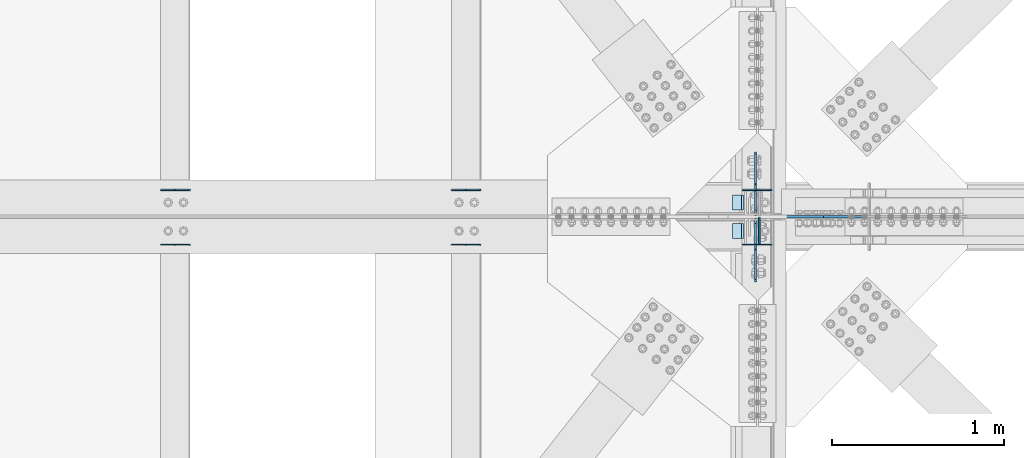
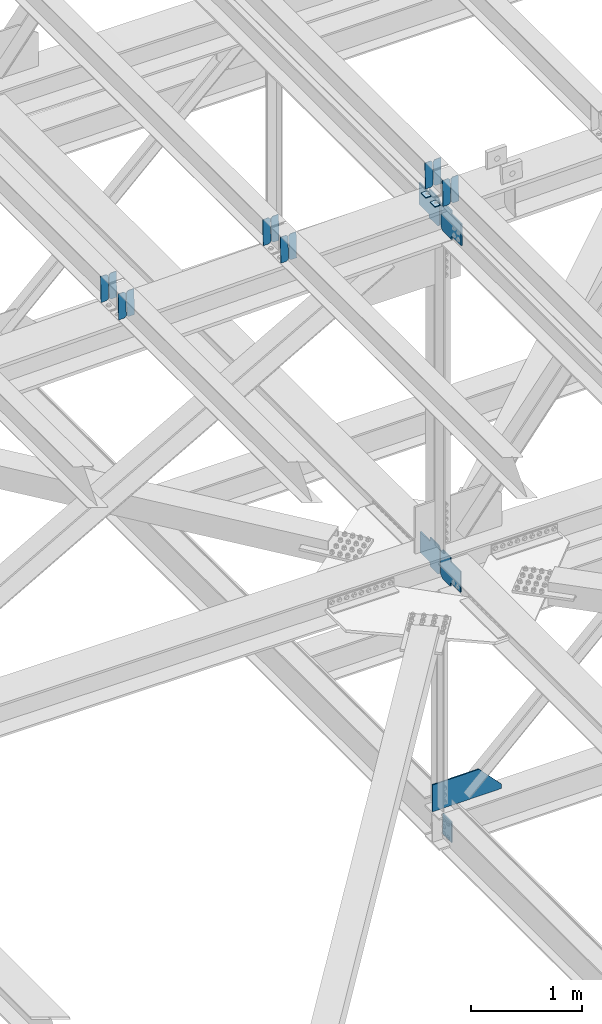
# One storey, part 3321 of 3843: 20 plates, 9 elements without a shape of their own.
"""IFC2X3 building model written with IfcOpenShell, lengths in millimetres."""

from ifc_helpers import new_model, si_unit, frame, origin_with_axes, place, context, subcontext, project, spatial, faceted_brep, material, type_object, element, aggregate, save


model = new_model("IFC2X3")

# Units and contexts
model_context = context("Model", 3, precision=1e-05, world=origin_with_axes())
body_context = subcontext(model_context, "Body", "Model", "MODEL_VIEW")
ifc_project = project(units=[si_unit("LENGTHUNIT", "METRE", prefix="MILLI"), si_unit("AREAUNIT", "SQUARE_METRE"), si_unit("VOLUMEUNIT", "CUBIC_METRE"), si_unit("MASSUNIT", "GRAM", prefix="KILO"), si_unit("TIMEUNIT", "SECOND"), si_unit("PLANEANGLEUNIT", "RADIAN"), si_unit("SOLIDANGLEUNIT", "STERADIAN"), si_unit("THERMODYNAMICTEMPERATUREUNIT", "DEGREE_CELSIUS"), si_unit("LUMINOUSINTENSITYUNIT", "LUMEN")], contexts=[model_context])

# Site, building, storey
site_placement = place(None, origin_with_axes())
site = spatial("IfcSite", under=ifc_project, at=site_placement, CompositionType="ELEMENT")
building_placement = place(site_placement, origin_with_axes())
building = spatial("IfcBuilding", under=site, at=building_placement, Name="Undefined", CompositionType="ELEMENT")
storey_placement = place(building_placement, origin_with_axes())
storey = spatial("IfcBuildingStorey", under=building, at=storey_placement, Name="Undefined", CompositionType="ELEMENT", Elevation=0.0)

# Assembly, plates
assembly_1_placement = place(storey_placement, origin_with_axes())
assembly_1 = element("IfcElementAssembly", 1, at=assembly_1_placement, inside=storey, Name="BEAM", AssemblyPlace="NOTDEFINED", PredefinedType="RIGID_FRAME")
ifc_material = material(Name="STEEL/A572-50")
plate_type_1 = type_object("IfcPlateType", PredefinedType="NOTDEFINED")
plate_1_placement = place(assembly_1_placement, frame((77095.0964783465, 59070.7010897801, 46382.6555246652), z_axis=(-0.0211520976064639, 0.000583214000143924, 0.999776099248365), x_axis=(-0.999776269355723, -1.23390000258365e-05, -0.0211520940075068)))
plate_1 = element("IfcPlate", 2, at=plate_1_placement, type_object=plate_type_1, material=ifc_material, Name="PLATE", context=body_context, shape_type="Brep", body=[
    faceted_brep([(0.0, -3.17499999999927, 0.0), (6.83940015733242e-10, -3.17499999996653, 288.924999998613), (6.54836185276508e-10, 3.17500000001746, 288.924999998591), (0.0, 3.17499999999927, 0.0), (60.3250007643655, -3.17500000017753, 288.924999998606), (60.3250007643219, 3.17499999979918, 288.924999998584), (79.3750000013097, -3.17500000025029, 269.875000761494), (79.375000001266, 3.17499999972642, 269.875000761487), (79.375000000713, -3.17500000026484, 19.0499992370605), (79.3750000006985, 3.17499999971187, 19.0499992370533), (60.325000763667, -3.17500000020664, -1.45519152283669e-11), (60.3250007636234, 3.17499999977736, -3.63797880709171e-11)], [[[0, 1, 2, 3]], [[1, 4, 5, 2]], [[4, 6, 7, 5]], [[6, 8, 9, 7]], [[8, 10, 11, 9]], [[10, 0, 3, 11]], [[5, 7, 9, 11, 3, 2]], [[10, 8, 6, 4, 1, 0]]]),
])
plate_2_placement = place(assembly_1_placement, frame((77009.3906576562, 59070.7000326944, 46380.8422613715), z_axis=(-0.0211520976064639, 0.000583214000143924, 0.999776099248365), x_axis=(-0.999776269355723, -1.23390000258365e-05, -0.0211520940075068)))
plate_2 = element("IfcPlate", 3, at=plate_2_placement, type_object=plate_type_1, material=ifc_material, Name="PLATE", context=body_context, shape_type="Brep", body=[
    faceted_brep([(4.36557456851006e-11, -3.17499999998836, 19.0499992370969), (6.11180439591408e-10, -3.17499999996653, 269.875000761516), (5.96628524363041e-10, 3.17500000001746, 269.875000761502), (1.45519152283669e-11, 3.17499999998836, 19.0499992370824), (19.0499992376572, -3.17500000003201, 288.924999998606), (19.0499992376281, 3.1749999999447, 288.924999998584), (79.3750000013242, -3.17500000025029, 288.924999998591), (79.3750000013097, 3.1749999997337, 288.92499999857), (79.3750000006548, -3.17500000026484, -2.18278728425503e-11), (79.3750000006403, 3.17499999969732, -2.91038304567337e-11), (19.0499992370023, -3.17500000005384, 0.0), (19.0499992369587, 3.17499999992287, -1.45519152283669e-11)], [[[0, 1, 2, 3]], [[1, 4, 5, 2]], [[4, 6, 7, 5]], [[6, 8, 9, 7]], [[8, 10, 11, 9]], [[10, 0, 3, 11]], [[5, 7, 9, 11, 3, 2]], [[10, 8, 6, 4, 1, 0]]]),
])

assembly_2_placement = place(storey_placement, origin_with_axes())
assembly_2 = element("IfcElementAssembly", 4, at=assembly_2_placement, inside=storey, Name="BEAM", AssemblyPlace="NOTDEFINED", PredefinedType="RIGID_FRAME")
plate_3_placement = place(assembly_2_placement, frame((77095.0964786592, 58753.5468079342, 46382.6529625895), z_axis=(-0.0211520975154853, -0.000575795999735418, 0.999776103550021), x_axis=(-0.999776269355722, 1.23390000256453e-05, -0.0211520940075457)))
plate_3 = element("IfcPlate", 5, at=plate_3_placement, type_object=plate_type_1, material=ifc_material, Name="PLATE", context=body_context, shape_type="Brep", body=[
    faceted_brep([(0.0, -3.17499999999927, 0.0), (6.83940015733242e-10, -3.17499999996653, 288.924999998613), (6.54836185276508e-10, 3.17500000001746, 288.924999998591), (0.0, 3.17499999999927, 0.0), (60.3250007643655, -3.17500000017753, 288.924999998606), (60.3250007643219, 3.17499999979918, 288.924999998584), (79.3750000013097, -3.17500000025029, 269.875000761494), (79.375000001266, 3.17499999972642, 269.875000761487), (79.375000000713, -3.17500000026484, 19.0499992370605), (79.3750000006985, 3.17499999971187, 19.0499992370533), (60.325000763667, -3.17500000020664, -1.45519152283669e-11), (60.3250007636234, 3.17499999977736, -3.63797880709171e-11)], [[[0, 1, 2, 3]], [[1, 4, 5, 2]], [[4, 6, 7, 5]], [[6, 8, 9, 7]], [[8, 10, 11, 9]], [[10, 0, 3, 11]], [[5, 7, 9, 11, 3, 2]], [[10, 8, 6, 4, 1, 0]]]),
])
plate_4_placement = place(assembly_2_placement, frame((77009.3906579689, 58753.5478522378, 46380.8396992902), z_axis=(-0.0211520975154853, -0.000575795999735418, 0.999776103550021), x_axis=(-0.999776269355722, 1.23390000256453e-05, -0.0211520940075457)))
plate_4 = element("IfcPlate", 6, at=plate_4_placement, type_object=plate_type_1, material=ifc_material, Name="PLATE", context=body_context, shape_type="Brep", body=[
    faceted_brep([(4.36557456851006e-11, -3.17499999998836, 19.0499992370969), (6.11180439591408e-10, -3.17499999996653, 269.875000761516), (5.96628524363041e-10, 3.17500000001746, 269.875000761502), (1.45519152283669e-11, 3.17499999998836, 19.0499992370824), (19.0499992376572, -3.17500000003201, 288.924999998606), (19.0499992376281, 3.1749999999447, 288.924999998584), (79.3750000013242, -3.17500000025029, 288.924999998591), (79.3750000013097, 3.1749999997337, 288.92499999857), (79.3750000006548, -3.17500000026484, -2.18278728425503e-11), (79.3750000006403, 3.17499999969732, -2.91038304567337e-11), (19.0499992370023, -3.17500000005384, 0.0), (19.0499992369587, 3.17499999992287, -1.45519152283669e-11)], [[[0, 1, 2, 3]], [[1, 4, 5, 2]], [[4, 6, 7, 5]], [[6, 8, 9, 7]], [[8, 10, 11, 9]], [[10, 0, 3, 11]], [[5, 7, 9, 11, 3, 2]], [[10, 8, 6, 4, 1, 0]]]),
])

assembly_3_placement = place(storey_placement, origin_with_axes())
assembly_3 = element("IfcElementAssembly", 7, at=assembly_3_placement, inside=storey, Name="BEAM", AssemblyPlace="NOTDEFINED", PredefinedType="RIGID_FRAME")
plate_5_placement = place(assembly_3_placement, frame((75405.9964817842, 59070.7097280611, 46349.1858286535), z_axis=(-0.0211520982414222, 0.000553894999946352, 0.999776115908114), x_axis=(-0.999776269355723, -1.23390000258365e-05, -0.0211520940075068)))
plate_5 = element("IfcPlate", 8, at=plate_5_placement, type_object=plate_type_1, material=ifc_material, Name="PLATE", context=body_context, shape_type="Brep", body=[
    faceted_brep([(0.0, -3.17499999999927, 0.0), (6.83940015733242e-10, -3.17499999996653, 288.924999998613), (6.54836185276508e-10, 3.17500000001746, 288.924999998591), (0.0, 3.17499999999927, 0.0), (60.3250007643655, -3.17500000017753, 288.924999998606), (60.3250007643219, 3.17499999979918, 288.924999998584), (79.3750000013097, -3.17500000025029, 269.875000761494), (79.375000001266, 3.17499999972642, 269.875000761487), (79.375000000713, -3.17500000026484, 19.0499992370605), (79.3750000006985, 3.17499999971187, 19.0499992370533), (60.325000763667, -3.17500000020664, -1.45519152283669e-11), (60.3250007636234, 3.17499999977736, -3.63797880709171e-11)], [[[0, 1, 2, 3]], [[1, 4, 5, 2]], [[4, 6, 7, 5]], [[6, 8, 9, 7]], [[8, 10, 11, 9]], [[10, 0, 3, 11]], [[5, 7, 9, 11, 3, 2]], [[10, 8, 6, 4, 1, 0]]]),
])
plate_6_placement = place(assembly_3_placement, frame((75320.2906610939, 59070.7087253666, 46347.3725653297), z_axis=(-0.0211520982414222, 0.000553894999946352, 0.999776115908114), x_axis=(-0.999776269355723, -1.23390000258365e-05, -0.0211520940075068)))
plate_6 = element("IfcPlate", 9, at=plate_6_placement, type_object=plate_type_1, material=ifc_material, Name="PLATE", context=body_context, shape_type="Brep", body=[
    faceted_brep([(4.36557456851006e-11, -3.17499999998836, 19.0499992370969), (6.11180439591408e-10, -3.17499999996653, 269.875000761516), (5.96628524363041e-10, 3.17500000001746, 269.875000761502), (1.45519152283669e-11, 3.17499999998836, 19.0499992370824), (19.0499992376572, -3.17500000003201, 288.924999998606), (19.0499992376281, 3.1749999999447, 288.924999998584), (79.3750000013242, -3.17500000025029, 288.924999998591), (79.3750000013097, 3.1749999997337, 288.92499999857), (79.3750000006548, -3.17500000026484, -2.18278728425503e-11), (79.3750000006403, 3.17499999969732, -2.91038304567337e-11), (19.0499992370023, -3.17500000005384, 0.0), (19.0499992369587, 3.17499999992287, -1.45519152283669e-11)], [[[0, 1, 2, 3]], [[1, 4, 5, 2]], [[4, 6, 7, 5]], [[6, 8, 9, 7]], [[8, 10, 11, 9]], [[10, 0, 3, 11]], [[5, 7, 9, 11, 3, 2]], [[10, 8, 6, 4, 1, 0]]]),
])
aggregate(assembly_3, [plate_5, plate_6])

assembly_4_placement = place(storey_placement, origin_with_axes())
assembly_4 = element("IfcElementAssembly", 10, at=assembly_4_placement, inside=storey, Name="BEAM", AssemblyPlace="NOTDEFINED", PredefinedType="RIGID_FRAME")
plate_7_placement = place(assembly_4_placement, frame((75405.99647837, 58753.539647001, 46349.1826475696), z_axis=(-0.0211520982287039, -0.000551804000038829, 0.99977611706465), x_axis=(-0.999776269355722, 1.23390000256453e-05, -0.0211520940075457)))
plate_7 = element("IfcPlate", 11, at=plate_7_placement, type_object=plate_type_1, material=ifc_material, Name="PLATE", context=body_context, shape_type="Brep", body=[
    faceted_brep([(0.0, -3.17499999999927, 0.0), (6.83940015733242e-10, -3.17499999996653, 288.924999998613), (6.54836185276508e-10, 3.17500000001746, 288.924999998591), (0.0, 3.17499999999927, 0.0), (60.3250007643655, -3.17500000017753, 288.924999998606), (60.3250007643219, 3.17499999979918, 288.924999998584), (79.3750000013097, -3.17500000025029, 269.875000761494), (79.375000001266, 3.17499999972642, 269.875000761487), (79.375000000713, -3.17500000026484, 19.0499992370605), (79.3750000006985, 3.17499999971187, 19.0499992370533), (60.325000763667, -3.17500000020664, -1.45519152283669e-11), (60.3250007636234, 3.17499999977736, -3.63797880709171e-11)], [[[0, 1, 2, 3]], [[1, 4, 5, 2]], [[4, 6, 7, 5]], [[6, 8, 9, 7]], [[8, 10, 11, 9]], [[10, 0, 3, 11]], [[5, 7, 9, 11, 3, 2]], [[10, 8, 6, 4, 1, 0]]]),
])
plate_8_placement = place(assembly_4_placement, frame((75320.2906576787, 58753.5406477902, 46347.369384245), z_axis=(-0.0211520982287039, -0.000551804000038829, 0.99977611706465), x_axis=(-0.999776269355722, 1.23390000256453e-05, -0.0211520940075457)))
plate_8 = element("IfcPlate", 12, at=plate_8_placement, type_object=plate_type_1, material=ifc_material, Name="PLATE", context=body_context, shape_type="Brep", body=[
    faceted_brep([(4.36557456851006e-11, -3.17499999998836, 19.0499992370969), (6.11180439591408e-10, -3.17499999996653, 269.875000761516), (5.96628524363041e-10, 3.17500000001746, 269.875000761502), (1.45519152283669e-11, 3.17499999998836, 19.0499992370824), (19.0499992376572, -3.17500000003201, 288.924999998606), (19.0499992376281, 3.1749999999447, 288.924999998584), (79.3750000013242, -3.17500000025029, 288.924999998591), (79.3750000013097, 3.1749999997337, 288.92499999857), (79.3750000006548, -3.17500000026484, -2.18278728425503e-11), (79.3750000006403, 3.17499999969732, -2.91038304567337e-11), (19.0499992370023, -3.17500000005384, 0.0), (19.0499992369587, 3.17499999992287, -1.45519152283669e-11)], [[[0, 1, 2, 3]], [[1, 4, 5, 2]], [[4, 6, 7, 5]], [[6, 8, 9, 7]], [[8, 10, 11, 9]], [[10, 0, 3, 11]], [[5, 7, 9, 11, 3, 2]], [[10, 8, 6, 4, 1, 0]]]),
])
aggregate(assembly_4, [plate_7, plate_8])

assembly_5_placement = place(storey_placement, origin_with_axes())
assembly_5 = element("IfcElementAssembly", 13, at=assembly_5_placement, inside=storey, Name="BEAM", AssemblyPlace="NOTDEFINED", PredefinedType="RIGID_FRAME")
plate_9_placement = place(assembly_5_placement, frame((73716.896478301, 59070.7155698843, 46315.1635973518), z_axis=(-0.0211520980283531, 0.000534327999768721, 0.999776126561636), x_axis=(-0.999776269357269, -1.03370000525781e-05, -0.0211520950075214)))
plate_9 = element("IfcPlate", 14, at=plate_9_placement, type_object=plate_type_1, material=ifc_material, Name="PLATE", context=body_context, shape_type="Brep", body=[
    faceted_brep([(0.0, -3.17499999999927, 0.0), (6.83940015733242e-10, -3.17499999996653, 288.924999998613), (6.54836185276508e-10, 3.17500000001746, 288.924999998591), (0.0, 3.17499999999927, 0.0), (60.3250007643655, -3.17500000017753, 288.924999998606), (60.3250007643219, 3.17499999979918, 288.924999998584), (79.3750000013097, -3.17500000025029, 269.875000761494), (79.375000001266, 3.17499999972642, 269.875000761487), (79.375000000713, -3.17500000026484, 19.0499992370605), (79.3750000006985, 3.17499999971187, 19.0499992370533), (60.325000763667, -3.17500000020664, -1.45519152283669e-11), (60.3250007636234, 3.17499999977736, -3.63797880709171e-11)], [[[0, 1, 2, 3]], [[1, 4, 5, 2]], [[4, 6, 7, 5]], [[6, 8, 9, 7]], [[8, 10, 11, 9]], [[10, 0, 3, 11]], [[5, 7, 9, 11, 3, 2]], [[10, 8, 6, 4, 1, 0]]]),
])
plate_10_placement = place(assembly_5_placement, frame((73631.1906576107, 59070.7146007914, 46313.3503340107), z_axis=(-0.0211520980283531, 0.000534327999768721, 0.999776126561636), x_axis=(-0.999776269357269, -1.03370000525781e-05, -0.0211520950075214)))
plate_10 = element("IfcPlate", 15, at=plate_10_placement, type_object=plate_type_1, material=ifc_material, Name="PLATE", context=body_context, shape_type="Brep", body=[
    faceted_brep([(4.36557456851006e-11, -3.17499999998836, 19.0499992370969), (6.11180439591408e-10, -3.17499999996653, 269.875000761516), (5.96628524363041e-10, 3.17500000001746, 269.875000761502), (1.45519152283669e-11, 3.17499999998836, 19.0499992370824), (19.0499992376572, -3.17500000003201, 288.924999998606), (19.0499992376281, 3.1749999999447, 288.924999998584), (79.3750000013242, -3.17500000025029, 288.924999998591), (79.3750000013097, 3.1749999997337, 288.92499999857), (79.3750000006548, -3.17500000026484, -2.18278728425503e-11), (79.3750000006403, 3.17499999969732, -2.91038304567337e-11), (19.0499992370023, -3.17500000005384, 0.0), (19.0499992369587, 3.17499999992287, -1.45519152283669e-11)], [[[0, 1, 2, 3]], [[1, 4, 5, 2]], [[4, 6, 7, 5]], [[6, 8, 9, 7]], [[8, 10, 11, 9]], [[10, 0, 3, 11]], [[5, 7, 9, 11, 3, 2]], [[10, 8, 6, 4, 1, 0]]]),
])
aggregate(assembly_5, [plate_9, plate_10])

assembly_6_placement = place(storey_placement, origin_with_axes())
assembly_6 = element("IfcElementAssembly", 16, at=assembly_6_placement, inside=storey, Name="BEAM", AssemblyPlace="NOTDEFINED", PredefinedType="RIGID_FRAME")
plate_11_placement = place(assembly_6_placement, frame((73716.8964782883, 58753.5324859493, 46315.1612598049), z_axis=(-0.0211520979550987, -0.000527811000014481, 0.99977613002494), x_axis=(-0.999776269357268, 1.0337000006824e-05, -0.0211520950075907)))
plate_11 = element("IfcPlate", 17, at=plate_11_placement, type_object=plate_type_1, material=ifc_material, Name="PLATE", context=body_context, shape_type="Brep", body=[
    faceted_brep([(0.0, -3.17499999999927, 0.0), (6.83940015733242e-10, -3.17499999996653, 288.924999998613), (6.54836185276508e-10, 3.17500000001746, 288.924999998591), (0.0, 3.17499999999927, 0.0), (60.3250007643655, -3.17500000017753, 288.924999998606), (60.3250007643219, 3.17499999979918, 288.924999998584), (79.3750000013097, -3.17500000025029, 269.875000761494), (79.375000001266, 3.17499999972642, 269.875000761487), (79.375000000713, -3.17500000026484, 19.0499992370605), (79.3750000006985, 3.17499999971187, 19.0499992370533), (60.325000763667, -3.17500000020664, -1.45519152283669e-11), (60.3250007636234, 3.17499999977736, -3.63797880709171e-11)], [[[0, 1, 2, 3]], [[1, 4, 5, 2]], [[4, 6, 7, 5]], [[6, 8, 9, 7]], [[8, 10, 11, 9]], [[10, 0, 3, 11]], [[5, 7, 9, 11, 3, 2]], [[10, 8, 6, 4, 1, 0]]]),
])
plate_12_placement = place(assembly_6_placement, frame((73631.1906575971, 58753.5334432234, 46313.3479964562), z_axis=(-0.0211520979550987, -0.000527811000014481, 0.99977613002494), x_axis=(-0.999776269357268, 1.0337000006824e-05, -0.0211520950075907)))
plate_12 = element("IfcPlate", 18, at=plate_12_placement, type_object=plate_type_1, material=ifc_material, Name="PLATE", context=body_context, shape_type="Brep", body=[
    faceted_brep([(4.36557456851006e-11, -3.17499999998836, 19.0499992370969), (6.11180439591408e-10, -3.17499999996653, 269.875000761516), (5.96628524363041e-10, 3.17500000001746, 269.875000761502), (1.45519152283669e-11, 3.17499999998836, 19.0499992370824), (19.0499992376572, -3.17500000003201, 288.924999998606), (19.0499992376281, 3.1749999999447, 288.924999998584), (79.3750000013242, -3.17500000025029, 288.924999998591), (79.3750000013097, 3.1749999997337, 288.92499999857), (79.3750000006548, -3.17500000026484, -2.18278728425503e-11), (79.3750000006403, 3.17499999969732, -2.91038304567337e-11), (19.0499992370023, -3.17500000005384, 0.0), (19.0499992369587, 3.17499999992287, -1.45519152283669e-11)], [[[0, 1, 2, 3]], [[1, 4, 5, 2]], [[4, 6, 7, 5]], [[6, 8, 9, 7]], [[8, 10, 11, 9]], [[10, 0, 3, 11]], [[5, 7, 9, 11, 3, 2]], [[10, 8, 6, 4, 1, 0]]]),
])
aggregate(assembly_6, [plate_11, plate_12])

# Plate
plate_type_2 = type_object("IfcPlateType", PredefinedType="NOTDEFINED")
plate_13_placement = place(assembly_1_placement, frame((76930.1677314818, 59042.3, 46372.9053533477), z_axis=(0.0, -1.0, 0.0), x_axis=(-0.999776270257024, 0.0, -0.0211520550054595)))
plate_13 = element("IfcPlate", 19, at=plate_13_placement, type_object=plate_type_2, material=ifc_material, Name="PLATE", context=body_context, shape_type="Brep", body=[
    faceted_brep([(9.52499999982683, -4.7625000001135, 88.8999999999942), (0.0, 4.76249999999709, 88.9000015258789), (0.0, 4.76249999999709, 0.0), (9.52499999981956, -4.76249999999709, 0.0), (63.4999984608512, -4.76249999988795, 88.8999999999796), (63.4999984608367, -4.76249999988795, -1.45519152283669e-11), (63.4999984608221, 4.76250000013533, -1.45519152283669e-11), (63.4999984608367, 4.76250000013533, 88.8999999999796)], [[[0, 1, 2, 3]], [[4, 5, 6, 7]], [[5, 4, 0, 3]], [[6, 5, 3, 2]], [[7, 6, 2, 1]], [[4, 7, 1, 0]]]),
])

aggregate(assembly_1, [plate_1, plate_2, plate_13])

plate_14_placement = place(assembly_2_placement, frame((76930.1677314818, 58877.2000015258, 46372.9053533477), z_axis=(0.0, -1.0, 0.0), x_axis=(-0.999776270257024, 0.0, -0.0211520550054595)))
plate_14 = element("IfcPlate", 20, at=plate_14_placement, type_object=plate_type_2, material=ifc_material, Name="PLATE", context=body_context, shape_type="Brep", body=[
    faceted_brep([(9.52499999982683, -4.7625000001135, 88.8999999999942), (0.0, 4.76249999999709, 88.9000015258789), (0.0, 4.76249999999709, 0.0), (9.52499999981956, -4.76249999999709, 0.0), (63.4999984608512, -4.76249999988795, 88.8999999999796), (63.4999984608367, -4.76249999988795, -1.45519152283669e-11), (63.4999984608221, 4.76250000013533, -1.45519152283669e-11), (63.4999984608367, 4.76250000013533, 88.8999999999796)], [[[0, 1, 2, 3]], [[4, 5, 6, 7]], [[5, 4, 0, 3]], [[6, 5, 3, 2]], [[7, 6, 2, 1]], [[4, 7, 1, 0]]]),
])

aggregate(assembly_2, [plate_3, plate_4, plate_14])

# Assembly, plates
assembly_7_placement = place(storey_placement, origin_with_axes())
assembly_7 = element("IfcElementAssembly", 21, at=assembly_7_placement, inside=storey, Name="BEAM", AssemblyPlace="NOTDEFINED", PredefinedType="RIGID_FRAME")
plate_type_3 = type_object("IfcPlateType", PredefinedType="NOTDEFINED")
plate_15_placement = place(assembly_7_placement, frame((77001.6875003496, 58922.44375, 42215.5928793205), z_axis=(0.0, 0.707106781186548, 0.707106781186548), x_axis=(5.70000238222118e-08, 0.707106781186546, -0.707106781186546)))
plate_15 = element("IfcPlate", 22, at=plate_15_placement, type_object=plate_type_3, material=ifc_material, Name="PLATE", context=body_context, shape_type="Brep", body=[
    faceted_brep([(0.0, -6.3499999046162, 0.0), (-179.592141809346, -6.35000000000582, 179.592141809349), (-179.592141809346, 6.35000000000582, 179.592141809349), (7.27595761418343e-12, 6.3499999046162, 0.0), (-179.592141809342, -6.35000000000582, 224.493422414482), (-179.592141809342, 6.35000000000582, 224.493422414482), (-75.7579304099854, -6.35000000000582, 328.327633813838), (-75.7579304099854, 6.35000000000582, 328.327633813838), (-53.2116423459665, -6.35000000000582, 305.781345749841), (-53.2116423459665, 6.35000000000582, 305.781345749841), (-49.0914658778274, -6.35000000000582, 303.02833184936), (-49.0914658778274, 6.35000000000582, 303.02833184936), (-44.2313863597883, -6.35000000000582, 302.061601926776), (-44.2313863597883, 6.35000000000582, 302.061601926776), (-39.3713068417637, -6.35000000000582, 303.02833184936), (-39.3713068417637, 6.35000000000582, 303.02833184936), (-35.2511303736173, -6.35000000000582, 305.781345749827), (-35.2511303736173, 6.35000000000582, 305.781345749827), (81.4921993345779, -6.35000000000582, 422.524675458029), (81.4921993345779, 6.35000000000582, 422.524675458029), (243.136809513038, -6.35000000000582, 260.880065279547), (243.136809513038, 6.35000000000582, 260.880065279547), (126.39347980485, -6.35000000000582, 144.136735571359), (126.39347980485, 6.35000000000582, 144.136735571359), (123.640465904376, -6.35000000000582, 140.016559103227), (123.640465904376, 6.35000000000582, 140.016559103227), (122.673735981793, -6.35000000000582, 135.156479585188), (122.673735981793, 6.35000000000582, 135.156479585188), (123.640465904384, -6.35000000000582, 130.296400067149), (123.640465904384, 6.35000000000582, 130.296400067149), (126.39347980485, -6.35000000000582, 126.176223599003), (126.39347980485, 6.35000000000582, 126.176223599003), (148.735492004496, -6.35000000000582, 103.834211399357), (148.735492004496, 6.35000000000582, 103.834211399357), (44.9012806051323, -6.35000000000582, -1.45519152283669e-11), (44.9012806051323, 6.35000000000582, -1.45519152283669e-11)], [[[0, 1, 2, 3]], [[1, 4, 5, 2]], [[4, 6, 7, 5]], [[6, 8, 9, 7]], [[8, 10, 11, 9]], [[10, 12, 13, 11]], [[12, 14, 15, 13]], [[14, 16, 17, 15]], [[16, 18, 19, 17]], [[18, 20, 21, 19]], [[20, 22, 23, 21]], [[22, 24, 25, 23]], [[24, 26, 27, 25]], [[26, 28, 29, 27]], [[28, 30, 31, 29]], [[30, 32, 33, 31]], [[32, 34, 35, 33]], [[34, 0, 3, 35]], [[5, 7, 9, 11, 13, 15, 17, 19, 21, 23, 25, 27, 29, 31, 33, 35, 3, 2]], [[34, 32, 30, 28, 26, 24, 22, 20, 18, 16, 14, 12, 10, 8, 6, 4, 1, 0]]]),
])
plate_16_placement = place(assembly_7_placement, frame((77001.6875001974, 58908.1562500577, 42215.592879264), z_axis=(0.0, -0.707106781186682, 0.707106781186413), x_axis=(0.0, -0.707106781186548, -0.707106781186548)))
plate_16 = element("IfcPlate", 23, at=plate_16_placement, type_object=plate_type_3, material=ifc_material, Name="PLATE", context=body_context, shape_type="Brep", body=[
    faceted_brep([(0.0, -6.3499999046162, 0.0), (-179.592141809346, -6.35000000000582, 179.592141809349), (-179.592141809346, 6.35000000000582, 179.592141809349), (7.27595761418343e-12, 6.3499999046162, 0.0), (-179.592141809342, -6.35000000000582, 224.493422414482), (-179.592141809342, 6.35000000000582, 224.493422414482), (-75.7579304099854, -6.35000000000582, 328.327633813838), (-75.7579304099854, 6.35000000000582, 328.327633813838), (-53.202618306881, -6.35000000000582, 305.772321792316), (-53.202618306881, 6.35000000000582, 305.772321792316), (-49.0824418387492, -6.35000000000582, 303.019307891842), (-49.0824418387492, 6.35000000000582, 303.019307891842), (-44.2223623207101, -6.35000000000582, 302.052577969262), (-44.2223623207101, 6.35000000000582, 302.052577969262), (-39.362282802671, -6.35000000000582, 303.019307891842), (-39.362282802671, 6.35000000000582, 303.019307891842), (-35.2421063345246, -6.35000000000582, 305.772321792319), (-35.2421063345246, 6.35000000000582, 305.772321792319), (81.5012233328598, -6.35000000000582, 422.515651459711), (81.5012233328598, 6.35000000000582, 422.515651459711), (243.145833511342, -6.35000000000582, 260.87104128124), (243.145833511342, 6.35000000000582, 260.87104128124), (126.402503843943, -6.35000000000582, 144.127711613848), (126.402503843943, 6.35000000000582, 144.127711613848), (123.649489943477, -6.35000000000582, 140.007535145705), (123.649489943477, 6.35000000000582, 140.007535145705), (122.682760020893, -6.35000000000582, 135.14745562767), (122.682760020893, 6.35000000000582, 135.14745562767), (123.649489943462, -6.35000000000582, 130.287376109631), (123.649489943462, 6.35000000000582, 130.287376109631), (126.402503843943, -6.35000000000582, 126.167199641492), (126.402503843943, 6.35000000000582, 126.167199641492), (148.735492004496, -6.35000000000582, 103.834211399357), (148.735492004496, 6.35000000000582, 103.834211399357), (44.9012806051323, -6.35000000000582, -1.45519152283669e-11), (44.9012806051323, 6.35000000000582, -1.45519152283669e-11)], [[[0, 1, 2, 3]], [[1, 4, 5, 2]], [[4, 6, 7, 5]], [[6, 8, 9, 7]], [[8, 10, 11, 9]], [[10, 12, 13, 11]], [[12, 14, 15, 13]], [[14, 16, 17, 15]], [[16, 18, 19, 17]], [[18, 20, 21, 19]], [[20, 22, 23, 21]], [[22, 24, 25, 23]], [[24, 26, 27, 25]], [[26, 28, 29, 27]], [[28, 30, 31, 29]], [[30, 32, 33, 31]], [[32, 34, 35, 33]], [[34, 0, 3, 35]], [[5, 7, 9, 11, 13, 15, 17, 19, 21, 23, 25, 27, 29, 31, 33, 35, 3, 2]], [[34, 32, 30, 28, 26, 24, 22, 20, 18, 16, 14, 12, 10, 8, 6, 4, 1, 0]]]),
])
aggregate(assembly_7, [plate_15, plate_16])

assembly_8_placement = place(storey_placement, origin_with_axes())
assembly_8 = element("IfcElementAssembly", 24, at=assembly_8_placement, inside=storey, Name="BEAM", AssemblyPlace="NOTDEFINED", PredefinedType="RIGID_FRAME")
plate_17_placement = place(assembly_8_placement, frame((77000.893749776, 58904.1875000653, 46045.8603342928), z_axis=(0.0, -0.707106781186682, 0.707106781186413), x_axis=(0.0, -0.707106781186548, -0.707106781186548)))
plate_17 = element("IfcPlate", 25, at=plate_17_placement, type_object=plate_type_3, material=ifc_material, Name="PLATE", context=body_context, shape_type="Brep", body=[
    faceted_brep([(0.0, -6.3499999046162, 0.0), (-179.472658463186, -6.35000000000582, 179.472658463195), (-179.472658463186, 6.35000000000582, 179.472658463195), (7.27595761418343e-12, 6.3499999046162, 0.0), (-179.472658463186, -6.35000000000582, 224.373939068324), (-179.472658463186, 6.35000000000582, 224.373939068324), (-68.3419889191136, -6.35000000000582, 335.504608612397), (-68.3419889191136, 6.35000000000582, 335.504608612397), (-50.5093363395863, -6.35000000000582, 317.671956032869), (-50.5093363395863, 6.35000000000582, 317.671956032869), (-46.3891598714399, -6.35000000000582, 314.918942132392), (-46.3891598714399, 6.35000000000582, 314.918942132392), (-41.5290803534008, -6.35000000000582, 313.952212209811), (-41.5290803534008, 6.35000000000582, 313.952212209811), (-36.6690008353762, -6.35000000000582, 314.918942132392), (-36.6690008353762, 6.35000000000582, 314.918942132392), (-32.5488243672298, -6.35000000000582, 317.671956032869), (-32.5488243672298, 6.35000000000582, 317.671956032869), (84.1945052945812, -6.35000000000582, 434.415285694673), (84.1945052945812, 6.35000000000582, 434.415285694673), (254.819371594058, -6.35000000000582, 263.790419395185), (254.819371594058, 6.35000000000582, 263.790419395185), (138.076041932261, -6.35000000000582, 147.047089733382), (138.076041932261, 6.35000000000582, 147.047089733382), (135.323028031795, -6.35000000000582, 142.926913265235), (135.323028031795, 6.35000000000582, 142.926913265235), (134.356298109211, -6.35000000000582, 138.0668337472), (134.356298109211, 6.35000000000582, 138.0668337472), (135.323028031795, -6.35000000000582, 133.206754229164), (135.323028031795, 6.35000000000582, 133.206754229164), (138.076041932261, -6.35000000000582, 129.086577761022), (138.076041932261, 6.35000000000582, 129.086577761022), (156.031950102829, -6.35000000000582, 111.130669497703), (156.031950102829, 6.35000000000582, 111.130669497703), (44.9012806051323, -6.35000000000582, -1.45519152283669e-11), (44.9012806051323, 6.35000000000582, -1.45519152283669e-11)], [[[0, 1, 2, 3]], [[1, 4, 5, 2]], [[4, 6, 7, 5]], [[6, 8, 9, 7]], [[8, 10, 11, 9]], [[10, 12, 13, 11]], [[12, 14, 15, 13]], [[14, 16, 17, 15]], [[16, 18, 19, 17]], [[18, 20, 21, 19]], [[20, 22, 23, 21]], [[22, 24, 25, 23]], [[24, 26, 27, 25]], [[26, 28, 29, 27]], [[28, 30, 31, 29]], [[30, 32, 33, 31]], [[32, 34, 35, 33]], [[34, 0, 3, 35]], [[5, 7, 9, 11, 13, 15, 17, 19, 21, 23, 25, 27, 29, 31, 33, 35, 3, 2]], [[34, 32, 30, 28, 26, 24, 22, 20, 18, 16, 14, 12, 10, 8, 6, 4, 1, 0]]]),
])
plate_18_placement = place(assembly_8_placement, frame((77000.8937495174, 58926.4125, 46045.8603346181), z_axis=(0.0, 0.707106781186548, 0.707106781186548), x_axis=(5.70000238222118e-08, 0.707106781186546, -0.707106781186546)))
plate_18 = element("IfcPlate", 26, at=plate_18_placement, type_object=plate_type_3, material=ifc_material, Name="PLATE", context=body_context, shape_type="Brep", body=[
    faceted_brep([(0.0, -6.3499999046162, 0.0), (-179.472658463186, -6.35000000000582, 179.472658463195), (-179.472658463186, 6.35000000000582, 179.472658463195), (7.27595761418343e-12, 6.3499999046162, 0.0), (-179.472658463186, -6.35000000000582, 224.373939068324), (-179.472658463186, 6.35000000000582, 224.373939068324), (-68.3419889191136, -6.35000000000582, 335.504608612397), (-68.3419889191136, 6.35000000000582, 335.504608612397), (-50.5083842768436, -6.35000000000582, 317.671003877404), (-50.5083842768436, 6.35000000000582, 317.671003877404), (-46.3882078086972, -6.35000000000582, 314.917989976937), (-46.3882078086972, 6.35000000000582, 314.917989976937), (-41.5281282906653, -6.35000000000582, 313.951260054353), (-41.5281282906653, 6.35000000000582, 313.951260054353), (-36.6680487726335, -6.35000000000582, 314.917989976937), (-36.6680487726335, 6.35000000000582, 314.917989976937), (-32.5478723044907, -6.35000000000582, 317.671003877404), (-32.5478723044907, 6.35000000000582, 317.671003877404), (84.1954574036718, -6.35000000000582, 434.414333585562), (84.1954574036718, 6.35000000000582, 434.414333585562), (254.820323703159, -6.35000000000582, 263.789467286071), (254.820323703159, 6.35000000000582, 263.789467286071), (138.076993995001, -6.35000000000582, 147.046137577927), (138.076993995001, 6.35000000000582, 147.046137577927), (135.32398009453, -6.35000000000582, 142.92596110978), (135.32398009453, 6.35000000000582, 142.92596110978), (134.357250171943, -6.35000000000582, 138.065881591741), (134.357250171943, 6.35000000000582, 138.065881591741), (135.32398009453, -6.35000000000582, 133.205802073717), (135.32398009453, 6.35000000000582, 133.205802073717), (138.076993994997, -6.35000000000582, 129.08562560557), (138.076993994997, 6.35000000000582, 129.08562560557), (156.031950102829, -6.35000000000582, 111.130669497703), (156.031950102829, 6.35000000000582, 111.130669497703), (44.9012806051323, -6.35000000000582, -1.45519152283669e-11), (44.9012806051323, 6.35000000000582, -1.45519152283669e-11)], [[[0, 1, 2, 3]], [[1, 4, 5, 2]], [[4, 6, 7, 5]], [[6, 8, 9, 7]], [[8, 10, 11, 9]], [[10, 12, 13, 11]], [[12, 14, 15, 13]], [[14, 16, 17, 15]], [[16, 18, 19, 17]], [[18, 20, 21, 19]], [[20, 22, 23, 21]], [[22, 24, 25, 23]], [[24, 26, 27, 25]], [[26, 28, 29, 27]], [[28, 30, 31, 29]], [[30, 32, 33, 31]], [[32, 34, 35, 33]], [[34, 0, 3, 35]], [[5, 7, 9, 11, 13, 15, 17, 19, 21, 23, 25, 27, 29, 31, 33, 35, 3, 2]], [[34, 32, 30, 28, 26, 24, 22, 20, 18, 16, 14, 12, 10, 8, 6, 4, 1, 0]]]),
])
aggregate(assembly_8, [plate_17, plate_18])

assembly_9_placement = place(storey_placement, origin_with_axes())
assembly_9 = element("IfcElementAssembly", 27, at=assembly_9_placement, inside=storey, Name="BEAM", AssemblyPlace="NOTDEFINED", PredefinedType="RIGID_FRAME")
plate_type_4 = type_object("IfcPlateType", PredefinedType="NOTDEFINED")
plate_19_placement = place(assembly_9_placement, frame((77023.1187499992, 58909.74375, 39570.0250000003), z_axis=(0.0, -1.0, 0.0), x_axis=(0.0, 0.0, -1.0)))
plate_19 = element("IfcPlate", 28, at=plate_19_placement, type_object=plate_type_4, material=ifc_material, Name="PLATE", context=body_context, shape_type="Brep", body=[
    faceted_brep([(0.0, -4.76249999999709, 0.0), (0.0, -4.76249999999709, 158.749999526888), (0.0, 4.76249999999709, 158.749999526888), (0.0, 4.76249999999709, 0.0), (228.599999999999, -4.76249999999709, 158.749999526888), (228.599999999999, 4.76249999999709, 158.749999526888), (228.600006103079, -4.7625000004482, 7.27595761418343e-12), (228.600006103079, 4.76249999954598, -7.27595761418343e-12)], [[[0, 1, 2, 3]], [[1, 4, 5, 2]], [[4, 6, 7, 5]], [[6, 0, 3, 7]], [[5, 7, 3, 2]], [[6, 4, 1, 0]]]),
])
plate_type_5 = type_object("IfcPlateType", PredefinedType="NOTDEFINED")
plate_20_placement = place(assembly_9_placement, frame((77628.1803143218, 58915.3, 39630.2666539288), z_axis=(-0.00872114900049929, 0.0, 0.999961970056917), x_axis=(-0.999961970056917, 0.0, -0.00872114900049944)))
plate_20 = element("IfcPlate", 29, at=plate_20_placement, type_object=plate_type_5, material=ifc_material, Name="PLATE", context=body_context, shape_type="Brep", body=[
    faceted_brep([(0.0, -6.3499999046162, 0.0), (1.01863406598568e-10, -6.34999999999854, 49.8870302500436), (1.01863406598568e-10, 6.34999999999854, 49.8870302500436), (7.27595761418343e-12, 6.3499999046162, 0.0), (229.075922550357, -6.34999999999854, 295.737575268446), (229.075922550357, 6.34999999999854, 295.737575268446), (714.42831255967, -6.34999999999854, 295.737575267369), (714.42831255967, 6.34999999999854, 295.737575267369), (717.007582107457, -6.34999999999854, -1.57160684466362e-09), (717.007582107457, 6.34999999999854, -1.57160684466362e-09)], [[[0, 1, 2, 3]], [[1, 4, 5, 2]], [[4, 6, 7, 5]], [[6, 8, 9, 7]], [[8, 0, 3, 9]], [[5, 7, 9, 3, 2]], [[8, 6, 4, 1, 0]]]),
])
aggregate(assembly_9, [plate_19, plate_20])

save(model, "model.ifc")
